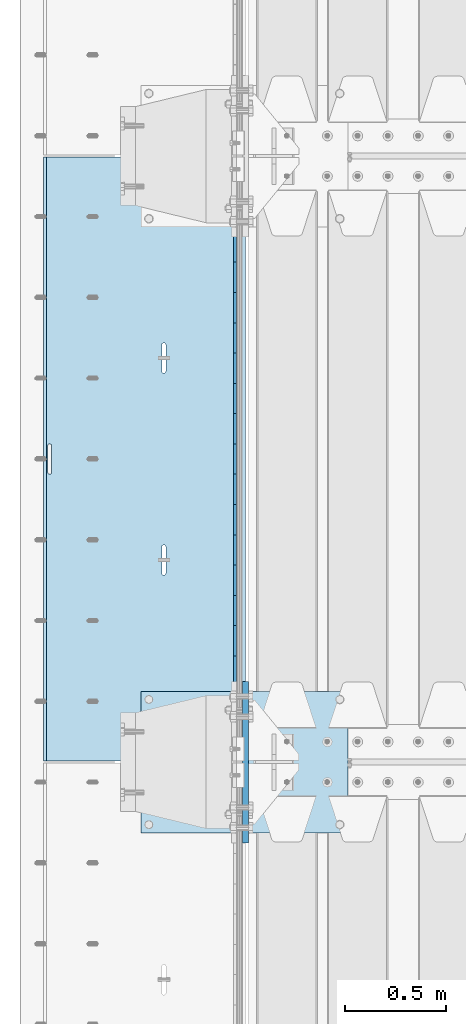
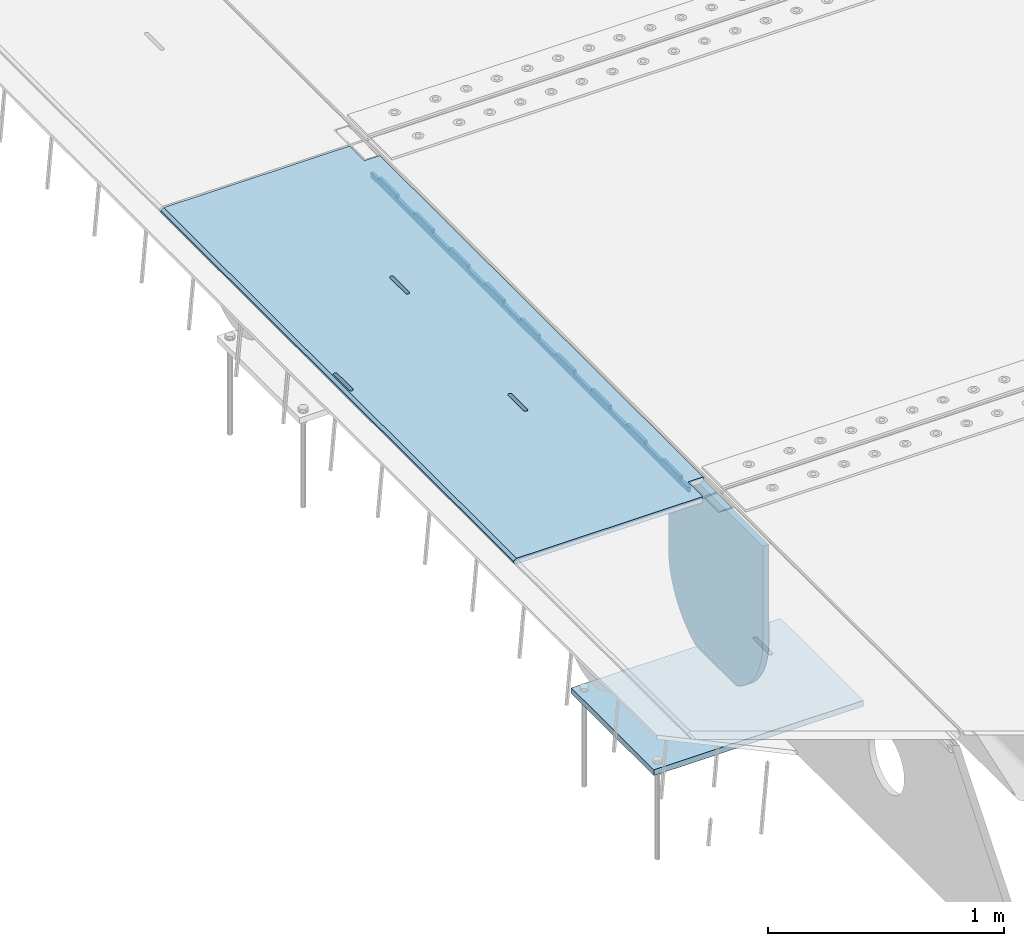
# One storey, part 190 of 247: 4 plates.
"""IFC2X3 building model written with IfcOpenShell, lengths in millimetres."""

from ifc_helpers import new_model, si_unit, frame, origin_with_axes, place, context, subcontext, project, spatial, faceted_brep, material, type_object, element, save


model = new_model("IFC2X3")

# Units and contexts
model_context = context("Model", 3, precision=1e-05, world=origin_with_axes())
body_context = subcontext(model_context, "Body", "Model", "MODEL_VIEW")
ifc_project = project(units=[si_unit("LENGTHUNIT", "METRE", prefix="MILLI"), si_unit("AREAUNIT", "SQUARE_METRE"), si_unit("VOLUMEUNIT", "CUBIC_METRE"), si_unit("MASSUNIT", "GRAM", prefix="KILO"), si_unit("TIMEUNIT", "SECOND"), si_unit("PLANEANGLEUNIT", "RADIAN"), si_unit("SOLIDANGLEUNIT", "STERADIAN"), si_unit("THERMODYNAMICTEMPERATUREUNIT", "DEGREE_CELSIUS"), si_unit("LUMINOUSINTENSITYUNIT", "LUMEN")], contexts=[model_context])

# Site, building, storey
site_placement = place(None, origin_with_axes())
site = spatial("IfcSite", under=ifc_project, at=site_placement, CompositionType="ELEMENT")
building_placement = place(site_placement, origin_with_axes())
building = spatial("IfcBuilding", under=site, at=building_placement, Name="Standard", CompositionType="ELEMENT")
storey_placement = place(building_placement, origin_with_axes())
storey = spatial("IfcBuildingStorey", under=building, at=storey_placement, Name="Undefined", CompositionType="ELEMENT", Elevation=0.0)

# Plates
ifc_material = material(Name="STEEL/S355N")
plate_type_1 = type_object("IfcPlateType", PredefinedType="NOTDEFINED")
plate_1_placement = place(storey_placement, frame((-5.00375433032989, 5994.99992617284, -1.00001208605641), z_axis=(1.00000000012752e-09, -0.999999999987744, -4.95099999993936e-06), x_axis=(-0.999999999879068, -1.00000022172504e-09, -1.55519999981193e-05)))
element("IfcPlate", 1, at=plate_1_placement, inside=storey, type_object=plate_type_1, material=ifc_material, context=body_context, shape_type="Brep", body=[
    faceted_brep([(-0.000111589569153026, -5.71507077660183e-05, 2865.00000504125), (15.0002388791539, 15.0, 2865.00008049103), (15.000010422308, 15.0, 125.000079348153), (-0.000225737458035447, 5.71560140554261e-05, 125.000003632548), (999.996459960937, 5.0, 1.36424205265939e-12), (984.996459960937, 15.0, 1.36424205265939e-12), (984.996459730713, 15.0, 2990.0), (999.996459730713, 5.0, 2990.0), (999.996459730713, -5.0, 2990.0), (984.99645973052, -15.0, 2990.0), (984.996459961366, -15.0, 1.81898940354586e-12), (999.996459960937, -4.99999999999999, 1.81898940354586e-12), (959.999522276415, -15.0000000031848, 1560.00000000851), (959.999522276415, 15.0, 1560.00000000851), (960.488957113225, 15.0, 1563.09016995226), (960.488957113226, -15.0000000031888, 1563.09016995226), (961.909352332213, 15.0, 1565.87785253144), (961.909352332213, -15.0000000032008, 1565.87785253143), (964.121669752867, 15.0, 1568.09016995226), (964.121669752867, -15.0000000032196, 1568.09016995226), (966.909352331933, 15.0, 1569.51056517146), (966.909352331933, -15.0000000032433, 1569.51056517146), (969.999522275633, 15.0, 1570.00000000851), (969.999522275633, -15.0000000032698, 1570.00000000851), (973.089692219423, 15.0, 1569.51056517146), (973.089692219423, -15.0000000032963, 1569.51056517146), (975.877374798709, 15.0, 1568.09016995226), (975.877374798709, -15.0000000033202, 1568.09016995226), (978.089692219704, 15.0, 1565.87785253143), (978.089692219704, -15.0000000033393, 1565.87785253143), (979.51008743912, 15.0, 1563.09016995225), (979.51008743912, -15.0000000033517, 1563.09016995225), (979.999522276403, 15.0, 1560.0000000085), (979.999522276403, -15.0000000033561, 1560.0000000085), (979.999522286261, 15.0, 1430.0000000085), (979.999522286261, -15.0000000033654, 1430.0000000085), (979.510087449448, 15.0, 1426.90983006475), (979.510087449448, -15.0000000033615, 1426.90983006475), (978.089692230459, 15.0, 1424.12214748558), (978.089692230459, -15.0000000033495, 1424.12214748558), (975.877374809805, 15.0, 1421.90983006476), (975.877374809805, -15.0000000033307, 1421.90983006476), (973.089692230741, 15.0, 1420.48943484556), (973.089692230741, -15.0000000033069, 1420.48943484556), (969.999522287193, 15.0, 1420.00000000851), (969.999522287193, -15.0000000032805, 1420.00000000851), (966.909352343406, 15.0, 1420.48943484556), (966.909352343406, -15.000000003254, 1420.48943484556), (964.121669764121, 15.0, 1421.90983006476), (964.121669764121, -15.00000000323, 1421.90983006476), (961.909352343126, 15.0, 1424.12214748559), (961.909352343126, -15.0000000032109, 1424.12214748559), (960.48895712371, 15.0, 1426.90983006476), (960.48895712371, -15.0000000031986, 1426.90983006476), (959.999522286423, 15.0, 1430.00000000851), (959.999522286423, -15.0000000031941, 1430.00000000851), (-0.000461899023638246, -14.9999999925605, 124.999928197261), (-0.000462055621302859, -14.9999999889596, 2864.99992960654), (75.0002624101966, 15.0, 125.000080471725), (74.9997898801964, -15.0, 124.999929601725), (74.9997820614451, -15.0, 4.54747350886464e-13), (75.0002485914438, 15.0, 0.0), (75.0005015105598, 15.0, 2990.0), (75.0000289805597, -15.0, 2990.0), (75.000491135538, 15.0, 2865.00008054905), (75.0000186055379, -14.999999997918, 2864.99992967905), (395.48895712147, -15.0, 1926.90983006544), (395.48895712147, 15.0, 1926.90983006544), (394.999522284184, 15.0, 1930.00000000919), (394.999522284184, -15.0, 1930.00000000919), (396.909352340887, -15.0, 1924.12214748626), (396.909352340887, 15.0, 1924.12214748626), (399.121669761882, -15.0, 1921.90983006544), (399.121669761882, 15.0, 1921.90983006544), (401.909352341167, -15.0, 1920.48943484623), (401.909352341167, 15.0, 1920.48943484623), (404.999522284954, -15.0, 1920.00000000919), (404.999522284954, 15.0, 1920.00000000919), (408.089692228525, -15.0, 1920.48943484623), (408.089692228525, 15.0, 1920.48943484623), (410.87737480759, -15.0, 1921.90983006543), (410.87737480759, 15.0, 1921.90983006543), (413.089692228244, -15.0, 1924.12214748626), (413.089692228244, 15.0, 1924.12214748626), (414.510087447233, -15.0, 1926.90983006543), (414.510087447233, 15.0, 1926.90983006543), (414.999522284046, -15.0, 1930.00000000918), (414.999522284046, 15.0, 1930.00000000918), (414.999522274166, -15.0, 2060.00000000918), (414.999522274166, 15.0, 2060.00000000918), (414.510087436882, -15.0, 2063.09016995293), (414.510087436882, 15.0, 2063.09016995293), (413.089692217466, -15.0, 2065.87785253211), (413.089692217466, 15.0, 2065.87785253211), (410.877374796471, -15.0, 2068.09016995293), (410.877374796471, 15.0, 2068.09016995293), (408.089692217185, -15.0, 2069.51056517214), (408.089692217185, 15.0, 2069.51056517214), (404.999522273396, -15.0, 2070.00000000919), (404.999522273396, 15.0, 2070.00000000919), (401.909352329694, -15.0, 2069.51056517214), (401.909352329694, 15.0, 2069.51056517214), (399.121669750628, -15.0, 2068.09016995294), (399.121669750628, 15.0, 2068.09016995294), (396.909352329974, -15.0, 2065.87785253211), (396.909352329974, 15.0, 2065.87785253211), (395.488957110986, -15.0, 2063.09016995294), (395.488957110986, 15.0, 2063.09016995294), (394.999522274176, -15.0, 2060.00000000919), (394.999522274176, 15.0, 2060.00000000919), (395.48895718799, -15.0, 1063.09016995158), (396.909352406977, -15.0, 1065.87785253076), (399.121669827631, -15.0, 1068.09016995158), (401.909352406696, -15.0, 1069.51056517079), (404.999522350398, -15.0, 1070.00000000783), (408.089692294187, -15.0, 1069.51056517079), (410.877374873473, -15.0, 1068.09016995158), (413.089692294469, -15.0, 1065.87785253076), (414.510087513885, -15.0, 1063.09016995158), (414.999522351169, -15.0, 1060.00000000783), (414.999522361049, -15.0, 930.000000007828), (414.510087524236, -15.0, 926.909830064081), (413.089692305248, -15.0, 924.122147484908), (410.877374884594, -15.0, 921.909830064085), (408.089692305529, -15.0, 920.489434844885), (404.999522361957, -15.0, 920.000000007837), (401.90935241817, -15.0, 920.489434844886), (399.121669838886, -15.0, 921.909830064089), (396.909352417891, -15.0, 924.122147484913), (395.488957198474, -15.0, 926.909830064088), (394.999522361188, -15.0, 930.000000007838), (394.999522351179, -15.0, 1060.00000000784), (396.90935241789, 15.0, 924.122147484913), (395.488957198474, 15.0, 926.909830064089), (399.121669838886, 15.0, 921.909830064088), (401.90935241817, 15.0, 920.489434844885), (404.999522361957, 15.0, 920.000000007838), (408.089692305529, 15.0, 920.489434844886), (410.877374884594, 15.0, 921.909830064085), (413.089692305248, 15.0, 924.122147484908), (414.510087524236, 15.0, 926.909830064081), (414.999522361049, 15.0, 930.000000007828), (414.999522351169, 15.0, 1060.00000000783), (414.510087513885, 15.0, 1063.09016995158), (413.089692294469, 15.0, 1065.87785253076), (410.877374873473, 15.0, 1068.09016995158), (408.089692294187, 15.0, 1069.51056517079), (404.999522350398, 15.0, 1070.00000000784), (401.909352406696, 15.0, 1069.51056517079), (399.121669827631, 15.0, 1068.09016995158), (396.909352406977, 15.0, 1065.87785253076), (395.48895718799, 15.0, 1063.09016995159), (394.999522351179, 15.0, 1060.00000000784), (394.999522361188, 15.0, 930.000000007838)], [[[0, 1, 2, 3]], [[4, 5, 6, 7]], [[8, 9, 10, 11]], [[12, 13, 14, 15]], [[15, 14, 16, 17]], [[17, 16, 18, 19]], [[19, 18, 20, 21]], [[21, 20, 22, 23]], [[23, 22, 24, 25]], [[25, 24, 26, 27]], [[27, 26, 28, 29]], [[29, 28, 30, 31]], [[31, 30, 32, 33]], [[33, 32, 34, 35]], [[35, 34, 36, 37]], [[37, 36, 38, 39]], [[39, 38, 40, 41]], [[41, 40, 42, 43]], [[43, 42, 44, 45]], [[45, 44, 46, 47]], [[47, 46, 48, 49]], [[49, 48, 50, 51]], [[51, 50, 52, 53]], [[53, 52, 54, 55]], [[55, 54, 13, 12]], [[56, 57, 0, 3]], [[58, 59, 56, 3, 2]], [[60, 59, 58, 61]], [[11, 10, 60, 61, 5, 4]], [[8, 11, 4, 7]], [[62, 63, 9, 8, 7, 6]], [[63, 62, 64, 65]], [[57, 65, 64, 1, 0]], [[66, 67, 68, 69]], [[70, 71, 67, 66]], [[72, 73, 71, 70]], [[74, 75, 73, 72]], [[76, 77, 75, 74]], [[78, 79, 77, 76]], [[80, 81, 79, 78]], [[82, 83, 81, 80]], [[84, 85, 83, 82]], [[86, 87, 85, 84]], [[88, 89, 87, 86]], [[90, 91, 89, 88]], [[92, 93, 91, 90]], [[94, 95, 93, 92]], [[96, 97, 95, 94]], [[98, 99, 97, 96]], [[100, 101, 99, 98]], [[102, 103, 101, 100]], [[104, 105, 103, 102]], [[106, 107, 105, 104]], [[108, 109, 107, 106]], [[69, 68, 109, 108]], [[63, 65, 57, 56, 59, 60, 10, 9], [15, 17, 19, 21, 23, 25, 27, 29, 31, 33, 35, 37, 39, 41, 43, 45, 47, 49, 51, 53, 55, 12], [110, 111, 112, 113, 114, 115, 116, 117, 118, 119, 120, 121, 122, 123, 124, 125, 126, 127, 128, 129, 130, 131], [106, 104, 102, 100, 98, 96, 94, 92, 90, 88, 86, 84, 82, 80, 78, 76, 74, 72, 70, 66, 69, 108]], [[128, 132, 133, 129]], [[127, 134, 132, 128]], [[126, 135, 134, 127]], [[125, 136, 135, 126]], [[124, 137, 136, 125]], [[123, 138, 137, 124]], [[122, 139, 138, 123]], [[121, 140, 139, 122]], [[120, 141, 140, 121]], [[119, 142, 141, 120]], [[118, 143, 142, 119]], [[117, 144, 143, 118]], [[116, 145, 144, 117]], [[115, 146, 145, 116]], [[114, 147, 146, 115]], [[113, 148, 147, 114]], [[112, 149, 148, 113]], [[111, 150, 149, 112]], [[110, 151, 150, 111]], [[131, 152, 151, 110]], [[130, 153, 152, 131]], [[129, 133, 153, 130]], [[64, 62, 6, 5, 61, 58, 2, 1], [50, 48, 46, 44, 42, 40, 38, 36, 34, 32, 30, 28, 26, 24, 22, 20, 18, 16, 14, 13, 54, 52], [132, 134, 135, 136, 137, 138, 139, 140, 141, 142, 143, 144, 145, 146, 147, 148, 149, 150, 151, 152, 153, 133], [71, 73, 75, 77, 79, 81, 83, 85, 87, 89, 91, 93, 95, 97, 99, 101, 103, 105, 107, 109, 68, 67]]]),
])
plate_type_2 = type_object("IfcPlateType", PredefinedType="NOTDEFINED")
plate_2_placement = place(storey_placement, frame((-57.5, 5845.00009940825, -36.0014545213866), z_axis=(1.00000000012752e-09, -0.999999999987744, -4.95099999993936e-06), x_axis=(0.0, 4.95099999111973e-06, -0.999999999987744)))
element("IfcPlate", 2, at=plate_2_placement, inside=storey, type_object=plate_type_2, material=ifc_material, context=body_context, shape_type="Brep", body=[
    faceted_brep([(0.0, -7.49999999999999, 0.0), (-1.24849464100407e-10, -7.5, 70.0), (-1.24849464100407e-10, 7.5, 70.0), (0.0, 7.5, 0.0), (-14.9899997711175, -7.5, 70.0), (-14.9899997711175, 7.5, 70.0), (-14.9899997711161, -7.5, 220.0), (-14.9899997711161, 7.5, 220.0), (-3.90834031804843e-10, -7.5, 220.0), (-3.90834031804843e-10, 7.5, 220.0), (-6.56818599509279e-10, -7.5, 370.0), (-6.56818599509279e-10, 7.5, 370.0), (-14.9899997711147, -7.5, 370.0), (-14.9899997711147, 7.5, 370.0), (-14.9899997711133, -7.5, 520.000000000001), (-14.9899997711133, 7.5, 520.000000000001), (-9.24629262044618e-10, -7.5, 520.000000000001), (-9.24629262044618e-10, 7.5, 520.000000000001), (-1.1906067243217e-09, -7.5, 669.999999999999), (-1.1906067243217e-09, 7.5, 669.999999999999), (-14.9899997711119, -7.5, 669.999999999999), (-14.9899997711119, 7.5, 669.999999999999), (-14.9899997711105, -7.5, 820.0), (-14.9899997711105, 7.5, 820.0), (-1.45477940804994e-09, -7.5, 820.0), (-1.45477940804994e-09, 7.5, 820.0), (-1.72257585973057e-09, -7.5, 970.0), (-1.72257585973057e-09, 7.5, 970.0), (-14.9899997711091, -7.5, 970.000000000001), (-14.9899997711091, 7.5, 970.000000000001), (-14.9899997711077, -7.5, 1120.0), (-14.9899997711077, 7.5, 1120.0), (-1.98856753286236e-09, -7.5, 1120.0), (-1.98856753286236e-09, 7.5, 1120.0), (-2.2545521005668e-09, -7.5, 1270.0), (-2.2545521005668e-09, 7.5, 1270.0), (-14.9899997711063, -7.5, 1270.0), (-14.9899997711063, 7.5, 1270.0), (-14.9899997711049, -7.5, 1420.0), (-14.9899997711049, 7.5, 1420.0), (-2.52235565767478e-09, -7.5, 1420.0), (-2.52235565767478e-09, 7.5, 1420.0), (-2.78834733080657e-09, -7.5, 1570.0), (-2.78834733080657e-09, 7.5, 1570.0), (-14.9899997711034, -7.5, 1570.0), (-14.9899997711034, 7.5, 1570.0), (-14.989999771102, -7.5, 1720.0), (-14.989999771102, 7.5, 1720.0), (-3.05433189851101e-09, -7.5, 1720.0), (-3.05433189851101e-09, 7.5, 1720.0), (-3.32212835019163e-09, -7.5, 1870.0), (-3.32212835019163e-09, 7.5, 1870.0), (-14.9899997711006, -7.5, 1870.0), (-14.9899997711006, 7.5, 1870.0), (-14.9899997710992, -7.5, 2020.0), (-14.9899997710992, 7.5, 2020.0), (-3.58812002332343e-09, -7.5, 2020.0), (-3.58812002332343e-09, 7.5, 2020.0), (-3.85410459102786e-09, -7.5, 2170.0), (-3.85410459102786e-09, 7.5, 2170.0), (-14.9899997710978, -7.5, 2170.0), (-14.9899997710978, 7.5, 2170.0), (-14.9899997710964, -7.5, 2320.0), (-14.9899997710964, 7.5, 2320.0), (-4.12190814813584e-09, -7.5, 2320.0), (-4.12190814813584e-09, 7.5, 2320.0), (-4.38789271584028e-09, -7.5, 2470.0), (-4.38789271584028e-09, 7.5, 2470.0), (-14.9999999999768, -7.5, 2470.0), (-14.9999999999768, 7.5, 2470.0), (-14.9899997710936, -7.5, 2620.0), (-14.9899997710936, 7.5, 2620.0), (-4.65388438897207e-09, -7.5, 2620.0), (-4.65388438897207e-09, 7.5, 2620.0), (-4.77873385307248e-09, -7.5, 2690.0), (-4.77873385307248e-09, 7.5, 2690.0), (25.0100002289071, -7.5, 2690.0), (25.0100002289071, 7.5, 2690.0), (25.0, -7.49999999999999, -1.81898940354586e-12), (25.0, 7.5, -1.81898940354586e-12)], [[[0, 1, 2, 3]], [[1, 4, 5, 2]], [[4, 6, 7, 5]], [[6, 8, 9, 7]], [[8, 10, 11, 9]], [[10, 12, 13, 11]], [[12, 14, 15, 13]], [[14, 16, 17, 15]], [[16, 18, 19, 17]], [[18, 20, 21, 19]], [[20, 22, 23, 21]], [[22, 24, 25, 23]], [[24, 26, 27, 25]], [[26, 28, 29, 27]], [[28, 30, 31, 29]], [[30, 32, 33, 31]], [[32, 34, 35, 33]], [[34, 36, 37, 35]], [[36, 38, 39, 37]], [[38, 40, 41, 39]], [[40, 42, 43, 41]], [[42, 44, 45, 43]], [[44, 46, 47, 45]], [[46, 48, 49, 47]], [[48, 50, 51, 49]], [[50, 52, 53, 51]], [[52, 54, 55, 53]], [[54, 56, 57, 55]], [[56, 58, 59, 57]], [[58, 60, 61, 59]], [[60, 62, 63, 61]], [[62, 64, 65, 63]], [[64, 66, 67, 65]], [[66, 68, 69, 67]], [[68, 70, 71, 69]], [[70, 72, 73, 71]], [[72, 74, 75, 73]], [[74, 76, 77, 75]], [[76, 78, 79, 77]], [[78, 0, 3, 79]], [[5, 7, 9, 11, 13, 15, 17, 19, 21, 23, 25, 27, 29, 31, 33, 35, 37, 39, 41, 43, 45, 47, 49, 51, 53, 55, 57, 59, 61, 63, 65, 67, 69, 71, 73, 75, 77, 79, 3, 2]], [[78, 76, 74, 72, 70, 68, 66, 64, 62, 60, 58, 56, 54, 52, 50, 48, 46, 44, 42, 40, 38, 36, 34, 32, 30, 28, 26, 24, 22, 20, 18, 16, 14, 12, 10, 8, 6, 4, 1, 0]]]),
])
plate_type_3 = type_object("IfcPlateType", PredefinedType="NOTDEFINED")
plate_3_placement = place(storey_placement, frame((-5.0, 2600.0, -20.0), z_axis=(0.0, 1.0, 0.0), x_axis=(0.0, 0.0, -1.0)))
element("IfcPlate", 3, at=plate_3_placement, inside=storey, type_object=plate_type_3, material=ifc_material, context=body_context, shape_type="Brep", body=[
    faceted_brep([(855.0, -15.0, 572.963114671537), (855.0, 15.0, 572.963114671537), (849.182410261294, 15.0, 585.889268817531), (849.182410261294, -15.0, 585.889268817531), (824.193546357474, 15.0, 627.225898692485), (824.193546357474, -15.0, 627.225898692485), (794.404299268454, 15.0, 665.249063296341), (794.404299268454, -15.0, 665.249063296341), (760.249063296334, 15.0, 699.404299268464), (760.249063296334, -15.0, 699.404299268464), (722.22589869248, 15.0, 729.193546357486), (722.22589869248, -15.0, 729.193546357486), (680.889268817528, 15.0, 754.182410261309), (680.889268817528, -15.0, 754.182410261309), (636.841954817037, 15.0, 774.006497074193), (636.841954817037, -15.0, 774.006497074193), (590.726265715048, 15.0, 788.37672697045), (590.726265715048, -15.0, 788.37672697045), (543.214672102156, 15.0, 797.083549639254), (543.214672102156, -15.0, 797.083549639254), (495.0, -15.0, 800.000000000029), (495.0, 15.0, 800.0), (494.999999999412, -15.0, 0.0), (494.999999999412, 15.0, 0.0), (543.214672102129, 15.0, 2.91645036080718), (543.214672102129, -15.0, 2.91645036080718), (590.726265715023, 15.0, 11.6232730296083), (590.726265715023, -15.0, 11.6232730296083), (636.841954817014, 15.0, 25.9935029258631), (636.841954817014, -15.0, 25.9935029258631), (680.889268817507, 15.0, 45.817589738745), (680.889268817507, -15.0, 45.817589738745), (722.225898692462, 15.0, 70.8064536425663), (722.225898692462, -15.0, 70.8064536425663), (760.249063296318, 15.0, 100.595700731589), (760.249063296318, -15.0, 100.595700731589), (794.404299268441, 15.0, 134.750936703711), (794.404299268441, -15.0, 134.750936703711), (824.193546357463, 15.0, 172.774101307567), (824.193546357463, -15.0, 172.774101307567), (849.182410261284, 15.0, 214.110731182522), (849.182410261284, -15.0, 214.110731182522), (855.0, -15.0, 227.036885328536), (855.0, 15.0, 227.036885328536), (0.0, -15.0, 0.0), (0.0, 15.0, 0.0), (0.0, 15.0, 800.0), (0.0, -15.0, 800.0)], [[[0, 1, 2, 3]], [[3, 2, 4, 5]], [[5, 4, 6, 7]], [[7, 6, 8, 9]], [[9, 8, 10, 11]], [[11, 10, 12, 13]], [[13, 12, 14, 15]], [[15, 14, 16, 17]], [[17, 16, 18, 19]], [[20, 19, 18, 21]], [[22, 23, 24, 25]], [[25, 24, 26, 27]], [[27, 26, 28, 29]], [[29, 28, 30, 31]], [[31, 30, 32, 33]], [[33, 32, 34, 35]], [[35, 34, 36, 37]], [[37, 36, 38, 39]], [[39, 38, 40, 41]], [[42, 41, 40, 43]], [[42, 43, 1, 0]], [[44, 45, 23, 22]], [[16, 14, 12, 10, 8, 6, 4, 2, 1, 43, 40, 38, 36, 34, 32, 30, 28, 26, 24, 23, 45, 46, 21, 18]], [[44, 47, 46, 45]], [[46, 47, 20, 21]], [[47, 44, 22, 25, 27, 29, 31, 33, 35, 37, 39, 41, 42, 0, 3, 5, 7, 9, 11, 13, 15, 17, 19, 20]]]),
])
plate_type_4 = type_object("IfcPlateType", PredefinedType="NOTDEFINED")
plate_4_placement = place(storey_placement, frame((-523.999999999996, 3350.0, -1043.0), z_axis=(1.0, 0.0, 0.0), x_axis=(0.0, -0.999999999999548, -9.5100000000016e-07)))
element("IfcPlate", 4, at=plate_4_placement, inside=storey, type_object=plate_type_4, material=ifc_material, context=body_context, shape_type="Brep", body=[
    faceted_brep([(0.0, -15.0, 0.0), (2.93249286187347e-06, -15.0, 1025.0), (2.93249286187347e-06, 15.0, 1025.0), (0.0, 15.0, 0.0), (700.0, -15.0, 1025.0), (700.0, 15.0, 1025.0), (700.0, -15.0, -6.3664629124105e-12), (700.0, 15.0, -6.3664629124105e-12)], [[[0, 1, 2, 3]], [[1, 4, 5, 2]], [[4, 6, 7, 5]], [[6, 0, 3, 7]], [[5, 7, 3, 2]], [[6, 4, 1, 0]]]),
])

save(model, "model.ifc")
